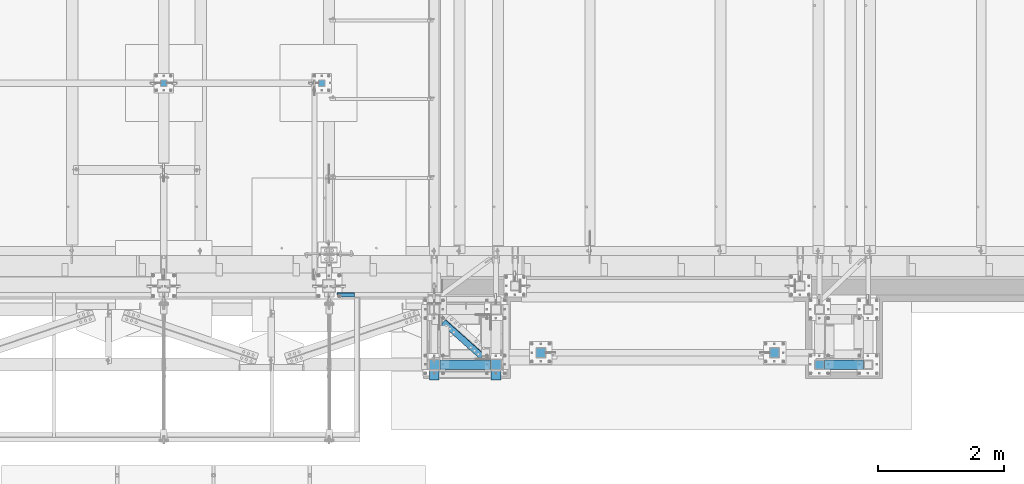
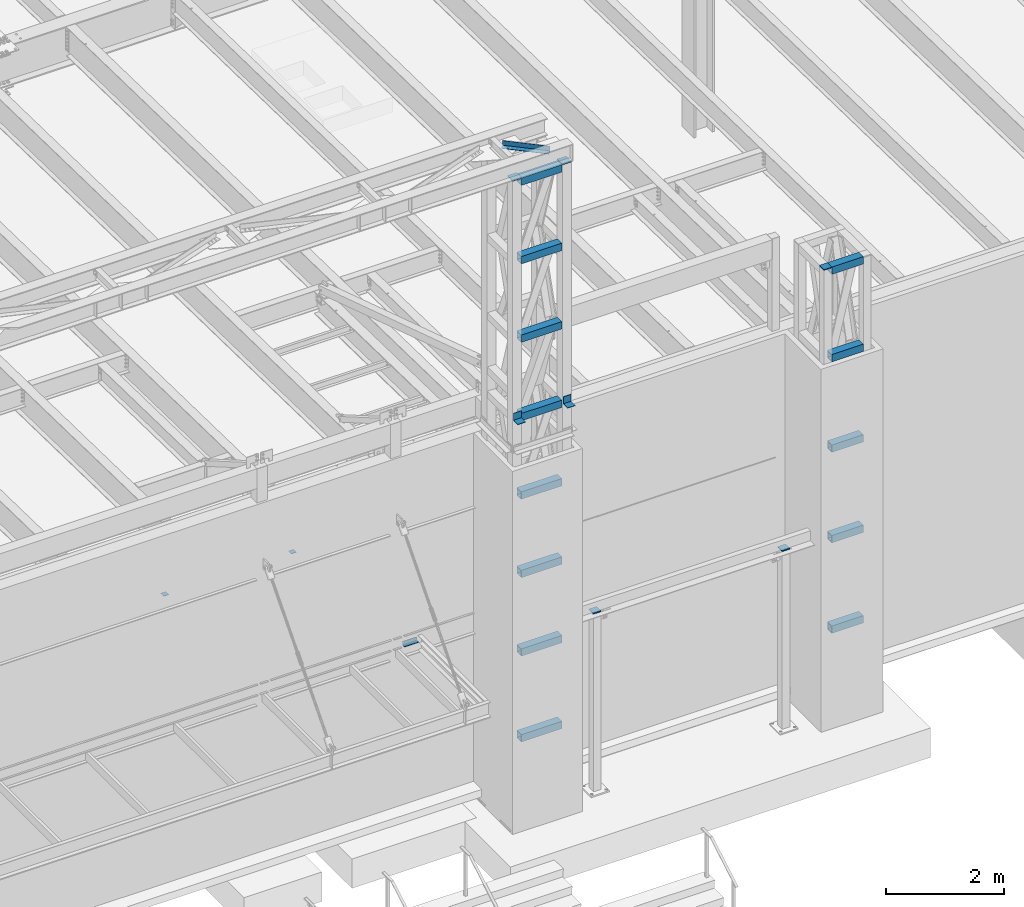
# One storey, part 1208 of 1763: 24 beams, 8 elements without a shape of their own.
"""IFC2X3 building model written with IfcOpenShell, lengths in millimetres."""

import ifcopenshell
import ifcopenshell.guid

model = None  # the IFC model being written
_history = None  # IfcOwnerHistory: only IFC2X3 demands one
_inside = {}  # id of a spatial element -> (the spatial element, [elements in it])
_under = {}  # id of a project, library or spatial element -> (it, [spatial elements below it])
_declared = {}  # id of a project -> (the project, [libraries it declares])
_typed = {}  # id of a type object -> (the type object, [elements of that type])
_made_of = {}  # id of a material, layer set ... -> (it, [elements and type objects made of it])


def new_model(schema):
    """Start an empty IFC model of exactly this schema.

    Asked for "IFC4X3", IfcOpenShell would pick the latest addendum, in which some entities
    have other attributes; the version numbers below select the first issue.
    IFC2X3 requires an IfcOwnerHistory on every rooted entity: one is made here for all.
    """
    global model, _history
    if schema == "IFC4X3":
        model = ifcopenshell.file(schema_version=(4, 3, 0, 0))
    else:
        model = ifcopenshell.file(schema=schema)
    _inside.clear()
    _under.clear()
    _declared.clear()
    _typed.clear()
    _made_of.clear()
    _history = None
    if model.schema == "IFC2X3":
        org = make("IfcOrganization", Name="unknown")
        user = make(
            "IfcPersonAndOrganization",
            ThePerson=make("IfcPerson", FamilyName="unknown"),
            TheOrganization=org,
        )
        app = make(
            "IfcApplication",
            ApplicationDeveloper=org,
            Version="unknown",
            ApplicationFullName="unknown",
            ApplicationIdentifier="unknown",
        )
        _history = make(
            "IfcOwnerHistory",
            OwningUser=user,
            OwningApplication=app,
            ChangeAction="ADDED",
            CreationDate=0,
        )
    return model


def make(cls, **values):
    """One entity of the class cls with the attributes given. An attribute that is None is left unset."""
    return model.create_entity(
        cls, **{name: value for name, value in values.items() if value is not None}
    )


def rooted(cls, **values):
    """An entity with a GlobalId (a new one), such as an element, a storey or a relation."""
    return make(cls, GlobalId=ifcopenshell.guid.new(), OwnerHistory=_history, **values)


def si_unit(unit_type, name, prefix=None):
    """IfcSIUnit, for example si_unit("LENGTHUNIT", "METRE", prefix="MILLI")."""
    return make("IfcSIUnit", UnitType=unit_type, Prefix=prefix, Name=name)


def assignment(units):
    """IfcUnitAssignment: the units of a project."""
    return None if units is None else make("IfcUnitAssignment", Units=units)


def point(xyz):
    """IfcCartesianPoint."""
    return None if xyz is None else make("IfcCartesianPoint", Coordinates=xyz)


def direction(xyz):
    """IfcDirection."""
    return None if xyz is None else make("IfcDirection", DirectionRatios=xyz)


def frame(location, z_axis=None, x_axis=None):
    """IfcAxis2Placement3D, a coordinate frame: its origin and axes. An axis left out is left unset."""
    return make(
        "IfcAxis2Placement3D",
        Location=point(location),
        Axis=direction(z_axis),
        RefDirection=direction(x_axis),
    )


def origin_with_axes():
    """The frame at (0, 0, 0) with the z axis (0, 0, 1) and the x axis (1, 0, 0) written out."""
    return frame((0.0, 0.0, 0.0), z_axis=(0.0, 0.0, 1.0), x_axis=(1.0, 0.0, 0.0))


def place(relative_to, where):
    """IfcLocalPlacement: puts the frame where relative to a parent placement (None: the world)."""
    return make(
        "IfcLocalPlacement", PlacementRelTo=relative_to, RelativePlacement=where
    )


def context(
    kind, dimensions, precision=None, world=None, true_north=None, identifier=None
):
    """IfcGeometricRepresentationContext, for example the 3D "Model" context."""
    return make(
        "IfcGeometricRepresentationContext",
        ContextIdentifier=identifier,
        ContextType=kind,
        CoordinateSpaceDimension=dimensions,
        Precision=precision,
        WorldCoordinateSystem=world,
        TrueNorth=true_north,
    )


def subcontext(parent, identifier, kind, view, scale=None):
    """IfcGeometricRepresentationSubContext, for example "Body" below "Model"."""
    return make(
        "IfcGeometricRepresentationSubContext",
        ContextIdentifier=identifier,
        ContextType=kind,
        ParentContext=parent,
        TargetScale=scale,
        TargetView=view,
    )


def project(units=None, contexts=None):
    """IfcProject with its units and contexts."""
    return rooted(
        "IfcProject",
        Name="project",
        RepresentationContexts=contexts,
        UnitsInContext=assignment(units),
    )


def spatial(cls, under=None, at=None, **own):
    """A site, building, storey or space (cls), placed at a placement, below another one or the project."""
    s = rooted(cls, ObjectPlacement=at, **own)
    if under is not None:
        _under.setdefault(under.id(), (under, []))[1].append(s)
    return s


def faces_of(points, faces, orient=None, outer=None):
    """IfcFace entities. A face is a list of loops; a loop is a list of indices into points, from 0.

    orient and outer hold one flag for each loop. By default every Orientation is true, the
    first loop of a face is its IfcFaceOuterBound and the others are IfcFaceBound.
    """
    made = []
    for i, loops in enumerate(faces):
        bounds = []
        for j, loop in enumerate(loops):
            is_outer = j == 0 if outer is None else outer[i][j]
            bounds.append(
                make(
                    "IfcFaceOuterBound" if is_outer else "IfcFaceBound",
                    Bound=make("IfcPolyLoop", Polygon=[points[k] for k in loop]),
                    Orientation=True if orient is None else orient[i][j],
                )
            )
        made.append(make("IfcFace", Bounds=bounds))
    return made


def faceted_brep(points, faces, orient=None, outer=None, voids=None):
    """IfcFacetedBrep: a solid bounded by flat faces; with voids (closed shells), ...WithVoids."""
    shared = [point(p) for p in points]
    hull = make("IfcClosedShell", CfsFaces=faces_of(shared, faces, orient, outer))
    if voids is None:
        return make("IfcFacetedBrep", Outer=hull)
    return make(
        "IfcFacetedBrepWithVoids",
        Outer=hull,
        Voids=[
            make(cls, CfsFaces=faces_of(shared, fs, o, b)) for cls, fs, o, b in voids
        ],
    )


def shape(context_of_items, identifier, shape_type, items):
    """IfcShapeRepresentation: the items that make up one representation, for example the "Body"."""
    return make(
        "IfcShapeRepresentation",
        ContextOfItems=context_of_items,
        RepresentationIdentifier=identifier,
        RepresentationType=shape_type,
        Items=items,
    )


def material(Name=None, Category=None):
    """IfcMaterial."""
    return make("IfcMaterial", Name=Name, Category=Category)


def made_of(thing, what):
    """Note that an element or type object is made of a material, layer set ...; save() writes the relation."""
    if what is not None:
        _made_of.setdefault(what.id(), (what, []))[1].append(thing)
    return thing


def type_object(cls, material=None, **own):
    """A type object (cls), such as IfcWallType, which elements share."""
    return made_of(rooted(cls, **own), material)


def element(
    cls,
    number,
    at=None,
    inside=None,
    cuts=None,
    type_object=None,
    material=None,
    context=None,
    identifier="Body",
    shape_type=None,
    held_by="IfcProductDefinitionShape",
    body=None,
    shapes=None,
    **own,
):
    """One element of the class cls, such as IfcWall. Its Tag is "e" and its number.

    at: its placement. inside: the storey or other place that contains it. cuts: it is an
    opening in that element (IfcRelVoidsElement). A single representation is given by context,
    identifier, shape_type and body (its items); several are given by shapes. held_by: the class
    of the entity that holds the representations. save() writes the other relations.
    """
    e = rooted(cls, Tag="e%d" % number, ObjectPlacement=at, **own)
    if body is not None:
        shapes = [shape(context, identifier, shape_type, body)]
    if shapes is not None:
        e.Representation = make(held_by, Representations=shapes)
    if inside is not None:
        _inside.setdefault(inside.id(), (inside, []))[1].append(e)
    if cuts is not None:
        rooted(
            "IfcRelVoidsElement", RelatingBuildingElement=cuts, RelatedOpeningElement=e
        )
    if type_object is not None:
        _typed.setdefault(type_object.id(), (type_object, []))[1].append(e)
    return made_of(e, material)


def aggregate(whole, parts):
    """IfcRelAggregates: a whole, such as a stair, and the parts it consists of."""
    return rooted("IfcRelAggregates", RelatingObject=whole, RelatedObjects=parts)


def save(model, path):
    """Write the relations noted so far, then the file.

    IfcRelAggregates (storeys below a building ...), IfcRelContainedInSpatialStructure (elements
    in a storey), IfcRelDefinesByType, IfcRelAssociatesMaterial and IfcRelDeclares: one each for
    every whole, place, type object, material and project.
    """
    for whole, parts in _under.values():
        aggregate(whole, parts)
    for where, things in _inside.values():
        rooted(
            "IfcRelContainedInSpatialStructure",
            RelatedElements=things,
            RelatingStructure=where,
        )
    for kind, things in _typed.values():
        rooted("IfcRelDefinesByType", RelatedObjects=things, RelatingType=kind)
    for what, things in _made_of.values():
        rooted("IfcRelAssociatesMaterial", RelatedObjects=things, RelatingMaterial=what)
    for by, libraries in _declared.values():
        rooted("IfcRelDeclares", RelatingContext=by, RelatedDefinitions=libraries)
    model.write(path)


model = new_model("IFC2X3")

# Units and contexts
model_context = context("Model", 3, precision=1e-05, world=origin_with_axes())
body_context = subcontext(model_context, "Body", "Model", "MODEL_VIEW")
ifc_project = project(units=[si_unit("LENGTHUNIT", "METRE", prefix="MILLI"), si_unit("AREAUNIT", "SQUARE_METRE"), si_unit("VOLUMEUNIT", "CUBIC_METRE"), si_unit("MASSUNIT", "GRAM", prefix="KILO"), si_unit("TIMEUNIT", "SECOND"), si_unit("PLANEANGLEUNIT", "RADIAN"), si_unit("SOLIDANGLEUNIT", "STERADIAN"), si_unit("THERMODYNAMICTEMPERATUREUNIT", "DEGREE_CELSIUS"), si_unit("LUMINOUSINTENSITYUNIT", "LUMEN")], contexts=[model_context])

# Site, building, storey
site_placement = place(None, origin_with_axes())
site = spatial("IfcSite", under=ifc_project, at=site_placement, CompositionType="ELEMENT")
building_placement = place(site_placement, origin_with_axes())
building = spatial("IfcBuilding", under=site, at=building_placement, Name="Undefined", CompositionType="ELEMENT")
storey_placement = place(building_placement, origin_with_axes())
storey = spatial("IfcBuildingStorey", under=building, at=storey_placement, Name="Undefined", CompositionType="ELEMENT", Elevation=0.0)

# Assembly, beam
assembly_1_placement = place(storey_placement, origin_with_axes())
assembly_1 = element("IfcElementAssembly", 1, at=assembly_1_placement, inside=storey, Name="ANGLE", AssemblyPlace="NOTDEFINED", PredefinedType="RIGID_FRAME")
ifc_material_1 = material(Name="STEEL/A36")
beam_type_1 = type_object("IfcBeamType", Name="L4X4X1/4", PredefinedType="NOTDEFINED")
beam_1_placement = place(assembly_1_placement, frame((-46794.6759782461, -15490.5665809142, 18672.175), z_axis=(-0.667212485940867, -0.744867436933988, 0.0), x_axis=(-0.744867436933987, 0.667212485940868, 0.0)))
beam_1 = element("IfcBeam", 2, at=beam_1_placement, type_object=beam_type_1, material=ifc_material_1, Name="ANGLE", ObjectType="L4X4X1/4", context=body_context, shape_type="Brep", body=[
    faceted_brep([(246.665849237292, -50.7999999999993, -44.4499999995605), (246.665849237281, -50.7999999999993, -50.7999999995518), (1070.58066999025, -50.7999999999993, -50.7999999982494), (1070.58066999025, -50.7999999999993, -44.4499999982581), (246.665849237292, 44.4500000000007, -44.4499999995605), (1070.58066999025, 44.4500000000007, -44.4499999982581), (246.665849237394, 44.4500000000007, 50.8000000003231), (1070.58066999036, 44.4500000000007, 50.8000000016327), (246.665849237394, 50.7999999999993, 50.8000000003231), (1070.58066999036, 50.7999999999993, 50.8000000016327), (246.665849237281, 50.7999999999993, -50.7999999995518), (1070.58066999025, 50.7999999999993, -50.7999999982494)], [[[0, 1, 2, 3]], [[4, 0, 3, 5]], [[6, 4, 5, 7]], [[8, 6, 7, 9]], [[1, 0, 4, 6, 8, 10]], [[1, 10, 11, 2]], [[7, 5, 3, 2, 11, 9]], [[10, 8, 9, 11]]]),
])
aggregate(assembly_1, [beam_1])

# Assembly, beams
assembly_2_placement = place(storey_placement, origin_with_axes())
assembly_2 = element("IfcElementAssembly", 3, at=assembly_2_placement, inside=storey, Name="FRAME", AssemblyPlace="NOTDEFINED", PredefinedType="RIGID_FRAME")
ifc_material_2 = material()
beam_type_2 = type_object("IfcBeamType", Name="HSS6X6X3/8", PredefinedType="NOTDEFINED")
beam_2_placement = place(assembly_2_placement, frame((-47735.5523997267, -15452.7272094127, 10248.70156), z_axis=(0.0, 0.0, 1.0), x_axis=(1.0, 0.0, 0.0)))
beam_2 = element("IfcBeam", 4, at=beam_2_placement, type_object=beam_type_2, material=ifc_material_2, Name="BEAM", ObjectType="HSS6X6X3/8", context=body_context, shape_type="Brep", body=[
    faceted_brep([(88.8999999999996, 66.6750000000029, -66.6749999999993), (88.8999999999996, -66.6750000000029, -66.6749999999993), (885.825195312507, -66.6749999999993, -66.6749999999993), (885.825158360378, 66.6749999998519, -66.6749999999993), (88.8999999999996, -66.6750000000029, 66.6749999999993), (885.825195312507, -66.6749999999993, 66.6749999999993), (88.8999999999996, 66.6750000000029, 66.6749999999993), (885.825158360378, 66.6749999998519, 66.6749999999993), (88.8999999999996, 76.1999999999971, -76.2000000000007), (88.8999999999996, 76.1999999999971, 76.2000000000007), (885.825180982218, 76.1999999998425, 76.2000000000007), (885.825180982218, 76.1999999998425, -76.2000000000007), (88.8999999999996, -76.1999999999971, 76.2000000000007), (885.825195312507, -76.2000000000007, 76.2000000000007), (88.8999999999996, -76.1999999999971, -76.2000000000007), (885.825195312507, -76.2000000000007, -76.2000000000007)], [[[0, 1, 2, 3]], [[1, 4, 5, 2]], [[4, 6, 7, 5]], [[6, 0, 3, 7]], [[8, 9, 10, 11]], [[9, 12, 13, 10]], [[12, 14, 15, 13]], [[14, 8, 11, 15]], [[13, 15, 11, 10], [5, 7, 3, 2]], [[14, 12, 9, 8], [6, 4, 1, 0]]]),
])
beam_3_placement = place(assembly_2_placement, frame((-47735.5523997267, -15452.7272094127, 11873.706248), z_axis=(0.0, 0.0, 1.0), x_axis=(1.0, 0.0, 0.0)))
beam_3 = element("IfcBeam", 5, at=beam_3_placement, type_object=beam_type_2, material=ifc_material_2, Name="BEAM", ObjectType="HSS6X6X3/8", context=body_context, shape_type="Brep", body=[
    faceted_brep([(88.8999999999996, 66.6750000000029, -66.6749999999993), (88.8999999999996, -66.6750000000029, -66.6749999999993), (885.825195312507, -66.6749999999993, -66.6749999999993), (885.825158360378, 66.6749999998519, -66.6749999999993), (88.8999999999996, -66.6750000000029, 66.6749999999993), (885.825195312507, -66.6749999999993, 66.6749999999993), (88.8999999999996, 66.6750000000029, 66.6749999999993), (885.825158360378, 66.6749999998519, 66.6749999999993), (88.8999999999996, 76.1999999999971, -76.2000000000007), (88.8999999999996, 76.1999999999971, 76.2000000000007), (885.825180982218, 76.1999999998425, 76.2000000000007), (885.825180982218, 76.1999999998425, -76.2000000000007), (88.8999999999996, -76.1999999999971, 76.2000000000007), (885.825195312507, -76.2000000000007, 76.2000000000007), (88.8999999999996, -76.1999999999971, -76.2000000000007), (885.825195312507, -76.2000000000007, -76.2000000000007)], [[[0, 1, 2, 3]], [[1, 4, 5, 2]], [[4, 6, 7, 5]], [[6, 0, 3, 7]], [[8, 9, 10, 11]], [[9, 12, 13, 10]], [[12, 14, 15, 13]], [[14, 8, 11, 15]], [[13, 15, 11, 10], [5, 7, 3, 2]], [[14, 12, 9, 8], [6, 4, 1, 0]]]),
])
beam_4_placement = place(assembly_2_placement, frame((-47735.5523997267, -15452.7272094127, 13498.710936), z_axis=(0.0, 0.0, 1.0), x_axis=(1.0, 0.0, 0.0)))
beam_4 = element("IfcBeam", 6, at=beam_4_placement, type_object=beam_type_2, material=ifc_material_2, Name="BEAM", ObjectType="HSS6X6X3/8", context=body_context, shape_type="Brep", body=[
    faceted_brep([(88.8999999999996, 66.6750000000029, -66.6749999999993), (88.8999999999996, -66.6750000000029, -66.6749999999993), (885.825195312507, -66.6749999999993, -66.6749999999993), (885.825158360378, 66.6749999998519, -66.6749999999993), (88.8999999999996, -66.6750000000029, 66.6749999999993), (885.825195312507, -66.6749999999993, 66.6749999999993), (88.8999999999996, 66.6750000000029, 66.6749999999993), (885.825158360378, 66.6749999998519, 66.6749999999993), (88.8999999999996, 76.1999999999971, -76.2000000000007), (88.8999999999996, 76.1999999999971, 76.2000000000007), (885.825180982218, 76.1999999998425, 76.2000000000007), (885.825180982218, 76.1999999998425, -76.2000000000007), (88.8999999999996, -76.1999999999971, 76.2000000000007), (885.825195312507, -76.2000000000007, 76.2000000000007), (88.8999999999996, -76.1999999999971, -76.2000000000007), (885.825195312507, -76.2000000000007, -76.2000000000007)], [[[0, 1, 2, 3]], [[1, 4, 5, 2]], [[4, 6, 7, 5]], [[6, 0, 3, 7]], [[8, 9, 10, 11]], [[9, 12, 13, 10]], [[12, 14, 15, 13]], [[14, 8, 11, 15]], [[13, 15, 11, 10], [5, 7, 3, 2]], [[14, 12, 9, 8], [6, 4, 1, 0]]]),
])
beam_5_placement = place(assembly_2_placement, frame((-47735.5523997267, -15452.7272094127, 15123.715624), z_axis=(0.0, 0.0, 1.0), x_axis=(1.0, 0.0, 0.0)))
beam_5 = element("IfcBeam", 7, at=beam_5_placement, type_object=beam_type_2, material=ifc_material_2, Name="BEAM", ObjectType="HSS6X6X3/8", context=body_context, shape_type="Brep", body=[
    faceted_brep([(88.8999999999996, 66.6750000000029, -66.6749999999993), (88.8999999999996, -66.6750000000029, -66.6749999999993), (885.825195312507, -66.6749999999993, -66.6749999999993), (885.825158360378, 66.6749999998519, -66.6749999999993), (88.8999999999996, -66.6750000000029, 66.6749999999993), (885.825195312507, -66.6749999999993, 66.6749999999993), (88.8999999999996, 66.6750000000029, 66.6749999999993), (885.825158360378, 66.6749999998519, 66.6749999999993), (88.8999999999996, 76.1999999999971, -76.2000000000007), (88.8999999999996, 76.1999999999971, 76.2000000000007), (885.825180982218, 76.1999999998425, 76.2000000000007), (885.825180982218, 76.1999999998425, -76.2000000000007), (88.8999999999996, -76.1999999999971, 76.2000000000007), (885.825195312507, -76.2000000000007, 76.2000000000007), (88.8999999999996, -76.1999999999971, -76.2000000000007), (885.825195312507, -76.2000000000007, -76.2000000000007)], [[[0, 1, 2, 3]], [[1, 4, 5, 2]], [[4, 6, 7, 5]], [[6, 0, 3, 7]], [[8, 9, 10, 11]], [[9, 12, 13, 10]], [[12, 14, 15, 13]], [[14, 8, 11, 15]], [[13, 15, 11, 10], [5, 7, 3, 2]], [[14, 12, 9, 8], [6, 4, 1, 0]]]),
])
beam_6_placement = place(assembly_2_placement, frame((-47735.5523997267, -15452.7272094127, 16748.720312), z_axis=(0.0, 0.0, 1.0), x_axis=(1.0, 0.0, 0.0)))
beam_6 = element("IfcBeam", 8, at=beam_6_placement, type_object=beam_type_2, material=ifc_material_2, Name="BEAM", ObjectType="HSS6X6X3/8", context=body_context, shape_type="Brep", body=[
    faceted_brep([(88.8999999999996, 66.6750000000029, -66.6749999999993), (88.8999999999996, -66.6750000000029, -66.6749999999993), (885.825195312507, -66.6749999999993, -66.6749999999993), (885.825158360378, 66.6749999998519, -66.6749999999993), (88.8999999999996, -66.6750000000029, 66.6749999999993), (885.825195312507, -66.6749999999993, 66.6749999999993), (88.8999999999996, 66.6750000000029, 66.6749999999993), (885.825158360378, 66.6749999998519, 66.6749999999993), (88.8999999999996, 76.1999999999971, -76.2000000000007), (88.8999999999996, 76.1999999999971, 76.2000000000007), (885.825180982218, 76.1999999998425, 76.2000000000007), (885.825180982218, 76.1999999998425, -76.2000000000007), (88.8999999999996, -76.1999999999971, 76.2000000000007), (885.825195312507, -76.2000000000007, 76.2000000000007), (88.8999999999996, -76.1999999999971, -76.2000000000007), (885.825195312507, -76.2000000000007, -76.2000000000007)], [[[0, 1, 2, 3]], [[1, 4, 5, 2]], [[4, 6, 7, 5]], [[6, 0, 3, 7]], [[8, 9, 10, 11]], [[9, 12, 13, 10]], [[12, 14, 15, 13]], [[14, 8, 11, 15]], [[13, 15, 11, 10], [5, 7, 3, 2]], [[14, 12, 9, 8], [6, 4, 1, 0]]]),
])
beam_7_placement = place(assembly_2_placement, frame((-47735.5523997267, -15452.7272094127, 18373.725), z_axis=(0.0, 0.0, 1.0), x_axis=(1.0, 0.0, 0.0)))
beam_7 = element("IfcBeam", 9, at=beam_7_placement, type_object=beam_type_2, material=ifc_material_2, Name="BEAM", ObjectType="HSS6X6X3/8", context=body_context, shape_type="Brep", body=[
    faceted_brep([(88.8999999999996, 66.6750000000029, -66.6749999999993), (88.8999999999996, -66.6750000000029, -66.6749999999993), (885.825195312507, -66.6749999999993, -66.6749999999993), (885.825158360378, 66.6749999998519, -66.6749999999993), (88.8999999999996, -66.6750000000029, 66.6749999999993), (885.825195312507, -66.6749999999993, 66.6749999999993), (88.8999999999996, 66.6750000000029, 66.6749999999993), (885.825158360378, 66.6749999998519, 66.6749999999993), (88.8999999999996, 76.1999999999971, -76.2000000000007), (88.8999999999996, 76.1999999999971, 76.2000000000007), (885.825180982218, 76.1999999998425, 76.2000000000007), (885.825180982218, 76.1999999998425, -76.2000000000007), (88.8999999999996, -76.1999999999971, 76.2000000000007), (885.825195312507, -76.2000000000007, 76.2000000000007), (88.8999999999996, -76.1999999999971, -76.2000000000007), (885.825195312507, -76.2000000000007, -76.2000000000007)], [[[0, 1, 2, 3]], [[1, 4, 5, 2]], [[4, 6, 7, 5]], [[6, 0, 3, 7]], [[8, 9, 10, 11]], [[9, 12, 13, 10]], [[12, 14, 15, 13]], [[14, 8, 11, 15]], [[13, 15, 11, 10], [5, 7, 3, 2]], [[14, 12, 9, 8], [6, 4, 1, 0]]]),
])
beam_8_placement = place(assembly_2_placement, frame((-47735.5523997267, -15452.7272094127, 8623.3), z_axis=(0.0, 0.0, 1.0), x_axis=(1.0, 0.0, 0.0)))
beam_8 = element("IfcBeam", 10, at=beam_8_placement, type_object=beam_type_2, material=ifc_material_2, Name="BEAM", ObjectType="HSS6X6X3/8", context=body_context, shape_type="Brep", body=[
    faceted_brep([(88.8999999999996, 66.6750000000029, -66.6749999999993), (88.8999999999996, -66.6750000000029, -66.6749999999993), (885.825195312507, -66.6749999999993, -66.6749999999993), (885.825158360378, 66.6749999998519, -66.6749999999993), (88.8999999999996, -66.6750000000029, 66.6749999999993), (885.825195312507, -66.6749999999993, 66.6749999999993), (88.8999999999996, 66.6750000000029, 66.6749999999993), (885.825158360378, 66.6749999998519, 66.6749999999993), (88.8999999999996, 76.1999999999971, -76.2000000000007), (88.8999999999996, 76.1999999999971, 76.2000000000007), (885.825180982218, 76.1999999998425, 76.2000000000007), (885.825180982218, 76.1999999998425, -76.2000000000007), (88.8999999999996, -76.1999999999971, 76.2000000000007), (885.825195312507, -76.2000000000007, 76.2000000000007), (88.8999999999996, -76.1999999999971, -76.2000000000007), (885.825195312507, -76.2000000000007, -76.2000000000007)], [[[0, 1, 2, 3]], [[1, 4, 5, 2]], [[4, 6, 7, 5]], [[6, 0, 3, 7]], [[8, 9, 10, 11]], [[9, 12, 13, 10]], [[12, 14, 15, 13]], [[14, 8, 11, 15]], [[13, 15, 11, 10], [5, 7, 3, 2]], [[14, 12, 9, 8], [6, 4, 1, 0]]]),
])
beam_9_placement = place(assembly_2_placement, frame((-47735.5523997267, -15452.7272094127, 6845.3), z_axis=(0.0, 0.0, 1.0), x_axis=(1.0, 0.0, 0.0)))
beam_9 = element("IfcBeam", 11, at=beam_9_placement, type_object=beam_type_2, material=ifc_material_2, Name="BEAM", ObjectType="HSS6X6X3/8", context=body_context, shape_type="Brep", body=[
    faceted_brep([(88.8999999999996, 66.6750000000029, -66.6749999999993), (88.8999999999996, -66.6750000000029, -66.6749999999993), (885.825195312507, -66.6749999999993, -66.6749999999993), (885.825158360378, 66.6749999998519, -66.6749999999993), (88.8999999999996, -66.6750000000029, 66.6749999999993), (885.825195312507, -66.6749999999993, 66.6749999999993), (88.8999999999996, 66.6750000000029, 66.6749999999993), (885.825158360378, 66.6749999998519, 66.6749999999993), (88.8999999999996, 76.1999999999971, -76.2000000000007), (88.8999999999996, 76.1999999999971, 76.2000000000007), (885.825180982218, 76.1999999998425, 76.2000000000007), (885.825180982218, 76.1999999998425, -76.2000000000007), (88.8999999999996, -76.1999999999971, 76.2000000000007), (885.825195312507, -76.2000000000007, 76.2000000000007), (88.8999999999996, -76.1999999999971, -76.2000000000007), (885.825195312507, -76.2000000000007, -76.2000000000007)], [[[0, 1, 2, 3]], [[1, 4, 5, 2]], [[4, 6, 7, 5]], [[6, 0, 3, 7]], [[8, 9, 10, 11]], [[9, 12, 13, 10]], [[12, 14, 15, 13]], [[14, 8, 11, 15]], [[13, 15, 11, 10], [5, 7, 3, 2]], [[14, 12, 9, 8], [6, 4, 1, 0]]]),
])

# Assembly, beam
assembly_3_placement = place(storey_placement, origin_with_axes())
assembly_3 = element("IfcElementAssembly", 12, at=assembly_3_placement, inside=storey, Name="FRAME", AssemblyPlace="NOTDEFINED", PredefinedType="RIGID_FRAME")
beam_type_3 = type_object("IfcBeamType", PredefinedType="NOTDEFINED")
beam_10_placement = place(assembly_3_placement, frame((-41639.5634959181, -15528.8556029674, 14468.475), z_axis=(1.0, 0.0, 0.0), x_axis=(0.0, 1.0, 0.0)))
beam_10 = element("IfcBeam", 13, at=beam_10_placement, type_object=beam_type_3, material=ifc_material_1, Name="PLATE", context=body_context, shape_type="Brep", body=[
    faceted_brep([(0.0, 9.52499999999964, -76.1999999999971), (0.0, 9.52499999999964, 76.1999999999971), (152.400000000001, 9.52499999999964, 76.1999999999971), (152.400000000001, 9.52499999999964, -76.1999999999971), (0.0, -9.52499999999964, 76.1999999999971), (152.400000000001, -9.52499999999964, 76.1999999999971), (0.0, -9.52499999999964, -76.1999999999971), (152.400000000001, -9.52499999999964, -76.1999999999971)], [[[0, 1, 2, 3]], [[1, 4, 5, 2]], [[4, 6, 7, 5]], [[6, 0, 3, 7]], [[5, 7, 3, 2]], [[6, 4, 1, 0]]]),
])

assembly_4_placement = place(storey_placement, origin_with_axes())
assembly_4 = element("IfcElementAssembly", 14, at=assembly_4_placement, inside=storey, Name="COLUMN", AssemblyPlace="NOTDEFINED", PredefinedType="RIGID_FRAME")
beam_11_placement = place(assembly_4_placement, frame((-42351.1710444319, -15341.6000613784, 8778.875), z_axis=(1.0, 0.0, 0.0), x_axis=(0.0, 1.0, 0.0)))
beam_11 = element("IfcBeam", 15, at=beam_11_placement, type_object=beam_type_3, material=ifc_material_1, Name="PLATE", context=body_context, shape_type="Brep", body=[
    faceted_brep([(0.0, 9.52499999999964, -76.1999999999971), (0.0, 9.52499999999964, 76.1999999999971), (152.400000000001, 9.52499999999964, 76.1999999999971), (152.400000000001, 9.52499999999964, -76.1999999999971), (0.0, -9.52499999999964, 76.1999999999971), (152.400000000001, -9.52499999999964, 76.1999999999971), (0.0, -9.52499999999964, -76.1999999999971), (152.400000000001, -9.52499999999964, -76.1999999999971)], [[[0, 1, 2, 3]], [[1, 4, 5, 2]], [[4, 6, 7, 5]], [[6, 0, 3, 7]], [[5, 7, 3, 2]], [[6, 4, 1, 0]]]),
])
aggregate(assembly_4, [beam_11])

assembly_5_placement = place(storey_placement, origin_with_axes())
assembly_5 = element("IfcElementAssembly", 16, at=assembly_5_placement, inside=storey, Name="COLUMN", AssemblyPlace="NOTDEFINED", PredefinedType="RIGID_FRAME")
beam_12_placement = place(assembly_5_placement, frame((-46049.6371287306, -15341.6000613784, 8778.875), z_axis=(1.0, 0.0, 0.0), x_axis=(0.0, 1.0, 0.0)))
beam_12 = element("IfcBeam", 17, at=beam_12_placement, type_object=beam_type_3, material=ifc_material_1, Name="PLATE", context=body_context, shape_type="Brep", body=[
    faceted_brep([(0.0, 9.52499999999964, -76.1999999999971), (0.0, 9.52499999999964, 76.1999999999971), (152.400000000001, 9.52499999999964, 76.1999999999971), (152.400000000001, 9.52499999999964, -76.1999999999971), (0.0, -9.52499999999964, 76.1999999999971), (152.400000000001, -9.52499999999964, 76.1999999999971), (0.0, -9.52499999999964, -76.1999999999971), (152.400000000001, -9.52499999999964, -76.1999999999971)], [[[0, 1, 2, 3]], [[1, 4, 5, 2]], [[4, 6, 7, 5]], [[6, 0, 3, 7]], [[5, 7, 3, 2]], [[6, 4, 1, 0]]]),
])
aggregate(assembly_5, [beam_12])

# Beam
beam_type_4 = type_object("IfcBeamType", Name="HSS6X6X5/8", PredefinedType="NOTDEFINED")
beam_13_placement = place(assembly_3_placement, frame((-41639.5633006091, -15452.6556029674, 6966.74375), z_axis=(0.0, 0.0, 1.0), x_axis=(1.0, 0.0, 0.0)))
beam_13 = element("IfcBeam", 18, at=beam_13_placement, type_object=beam_type_4, material=ifc_material_2, Name="BEAM", ObjectType="HSS6X6X5/8", context=body_context, shape_type="Brep", body=[
    faceted_brep([(76.1998535156017, 60.3250000000007, -60.3249999999998), (76.1998535156017, -60.3250000000007, -60.3249999999998), (695.325048828119, -60.3250000000007, -60.3249999999998), (695.325048828119, 60.3250000000007, -60.3249999999998), (76.1998535156017, -60.3250000000007, 60.3249999999998), (695.325048828119, -60.3250000000007, 60.3249999999998), (76.1998535156017, 60.3250000000007, 60.3249999999998), (695.325048828119, 60.3250000000007, 60.3249999999998), (76.1998535156017, 76.2000000000007, -76.1999999999998), (76.1998535156017, 76.2000000000007, 76.1999999999998), (695.325048828119, 76.2000000000007, 76.1999999999998), (695.325048828119, 76.2000000000007, -76.1999999999998), (76.1998535156017, -76.2000000000007, 76.1999999999998), (695.325048828119, -76.2000000000007, 76.1999999999998), (76.1998535156017, -76.2000000000007, -76.1999999999998), (695.325048828119, -76.2000000000007, -76.1999999999998)], [[[0, 1, 2, 3]], [[1, 4, 5, 2]], [[4, 6, 7, 5]], [[6, 0, 3, 7]], [[8, 9, 10, 11]], [[9, 12, 13, 10]], [[12, 14, 15, 13]], [[14, 8, 11, 15]], [[13, 15, 11, 10], [5, 7, 3, 2]], [[14, 12, 9, 8], [6, 4, 1, 0]]]),
])

beam_14_placement = place(assembly_3_placement, frame((-41639.5633006125, -15452.6556029674, 8840.7875), z_axis=(0.0, 0.0, 1.0), x_axis=(1.0, 0.0, 0.0)))
beam_14 = element("IfcBeam", 19, at=beam_14_placement, type_object=beam_type_4, material=ifc_material_2, Name="BEAM", ObjectType="HSS6X6X5/8", context=body_context, shape_type="Brep", body=[
    faceted_brep([(76.1999511718459, 60.3250000000007, -60.3250000000007), (76.1999511718459, -60.3250000000007, -60.3250000000007), (695.325146484363, -60.3250000000007, -60.3250000000007), (695.325146484363, 60.3250000000007, -60.3250000000007), (76.1999511718459, -60.3250000000007, 60.3250000000007), (695.325146484363, -60.3250000000007, 60.3250000000007), (76.1999511718459, 60.3250000000007, 60.3250000000007), (695.325146484363, 60.3250000000007, 60.3250000000007), (76.1999511718459, 76.2000000000007, -76.2000000000007), (76.1999511718459, 76.2000000000007, 76.2000000000007), (695.325146484363, 76.2000000000007, 76.2000000000007), (695.325146484363, 76.2000000000007, -76.2000000000007), (76.1999511718459, -76.2000000000007, 76.2000000000007), (695.325146484363, -76.2000000000007, 76.2000000000007), (76.1999511718459, -76.2000000000007, -76.2000000000007), (695.325146484363, -76.2000000000007, -76.2000000000007)], [[[0, 1, 2, 3]], [[1, 4, 5, 2]], [[4, 6, 7, 5]], [[6, 0, 3, 7]], [[8, 9, 10, 11]], [[9, 12, 13, 10]], [[12, 14, 15, 13]], [[14, 8, 11, 15]], [[13, 15, 11, 10], [5, 7, 3, 2]], [[14, 12, 9, 8], [6, 4, 1, 0]]]),
])

beam_15_placement = place(assembly_3_placement, frame((-41639.5633006159, -15452.6556029674, 10714.83125), z_axis=(0.0, 0.0, 1.0), x_axis=(1.0, 0.0, 0.0)))
beam_15 = element("IfcBeam", 20, at=beam_15_placement, type_object=beam_type_4, material=ifc_material_2, Name="BEAM", ObjectType="HSS6X6X5/8", context=body_context, shape_type="Brep", body=[
    faceted_brep([(76.1999511718459, 60.3250000000007, -60.3250000000007), (76.1999511718459, -60.3250000000007, -60.3250000000007), (695.325146484363, -60.3250000000007, -60.3250000000007), (695.325146484363, 60.3250000000007, -60.3250000000007), (76.1999511718459, -60.3250000000007, 60.3250000000007), (695.325146484363, -60.3250000000007, 60.3250000000007), (76.1999511718459, 60.3250000000007, 60.3250000000007), (695.325146484363, 60.3250000000007, 60.3250000000007), (76.1999511718459, 76.2000000000007, -76.2000000000007), (76.1999511718459, 76.2000000000007, 76.2000000000007), (695.325146484363, 76.2000000000007, 76.2000000000007), (695.325146484363, 76.2000000000007, -76.2000000000007), (76.1999511718459, -76.2000000000007, 76.2000000000007), (695.325146484363, -76.2000000000007, 76.2000000000007), (76.1999511718459, -76.2000000000007, -76.2000000000007), (695.325146484363, -76.2000000000007, -76.2000000000007)], [[[0, 1, 2, 3]], [[1, 4, 5, 2]], [[4, 6, 7, 5]], [[6, 0, 3, 7]], [[8, 9, 10, 11]], [[9, 12, 13, 10]], [[12, 14, 15, 13]], [[14, 8, 11, 15]], [[13, 15, 11, 10], [5, 7, 3, 2]], [[14, 12, 9, 8], [6, 4, 1, 0]]]),
])

beam_16_placement = place(assembly_3_placement, frame((-41639.5633006226, -15452.6556029674, 14401.8), z_axis=(0.0, 0.0, 1.0), x_axis=(1.0, 0.0, 0.0)))
beam_16 = element("IfcBeam", 21, at=beam_16_placement, type_object=beam_type_4, material=ifc_material_2, Name="BEAM", ObjectType="HSS6X6X5/8", context=body_context, shape_type="Brep", body=[
    faceted_brep([(76.1999511718459, 60.3250000000007, -60.3250000000007), (76.1999511718459, -60.3250000000007, -60.3250000000007), (695.325146484363, -60.3250000000007, -60.3250000000007), (695.325146484363, 60.3250000000007, -60.3250000000007), (76.2000027795075, -60.3250000000007, 60.3250000000007), (695.32519809201, -60.3250000000007, 60.3250000000007), (76.2000027795075, 60.3250000000007, 60.3250000000007), (695.32519809201, 60.3250000000007, 60.3250000000007), (76.1999511718459, 76.2000000000007, -76.2000000000007), (76.2000031128846, 76.2000000000007, 76.2000000000007), (695.325198425387, 76.2000000000007, 76.2000000000007), (695.325146484363, 76.2000000000007, -76.2000000000007), (76.2000031128846, -76.2000000000007, 76.2000000000007), (695.325198425387, -76.2000000000007, 76.2000000000007), (76.1999511718459, -76.2000000000007, -76.2000000000007), (695.325146484363, -76.2000000000007, -76.2000000000007)], [[[0, 1, 2, 3]], [[1, 4, 5, 2]], [[4, 6, 7, 5]], [[6, 0, 3, 7]], [[8, 9, 10, 11]], [[9, 12, 13, 10]], [[12, 14, 15, 13]], [[14, 8, 11, 15]], [[13, 15, 11, 10], [5, 7, 3, 2]], [[14, 12, 9, 8], [6, 4, 1, 0]]]),
])

beam_17_placement = place(assembly_3_placement, frame((-41639.5633006194, -15452.6556029674, 12588.875), z_axis=(0.0, 0.0, 1.0), x_axis=(1.0, 0.0, 0.0)))
beam_17 = element("IfcBeam", 22, at=beam_17_placement, type_object=beam_type_4, material=ifc_material_2, Name="BEAM", ObjectType="HSS6X6X5/8", context=body_context, shape_type="Brep", body=[
    faceted_brep([(76.1999511718459, 60.3250000000007, -60.3250000000007), (76.1999511718459, -60.3250000000007, -60.3250000000007), (695.325146484363, -60.3250000000007, -60.3250000000007), (695.325146484363, 60.3250000000007, -60.3250000000007), (76.2000027795075, -60.3250000000007, 60.3250000000007), (695.32519809201, -60.3250000000007, 60.3250000000007), (76.2000027795075, 60.3250000000007, 60.3250000000007), (695.32519809201, 60.3250000000007, 60.3250000000007), (76.1999511718459, 76.2000000000007, -76.2000000000007), (76.2000031128846, 76.2000000000007, 76.2000000000007), (695.325198425387, 76.2000000000007, 76.2000000000007), (695.325146484363, 76.2000000000007, -76.2000000000007), (76.2000031128846, -76.2000000000007, 76.2000000000007), (695.325198425387, -76.2000000000007, 76.2000000000007), (76.1999511718459, -76.2000000000007, -76.2000000000007), (695.325146484363, -76.2000000000007, -76.2000000000007)], [[[0, 1, 2, 3]], [[1, 4, 5, 2]], [[4, 6, 7, 5]], [[6, 0, 3, 7]], [[8, 9, 10, 11]], [[9, 12, 13, 10]], [[12, 14, 15, 13]], [[14, 8, 11, 15]], [[13, 15, 11, 10], [5, 7, 3, 2]], [[14, 12, 9, 8], [6, 4, 1, 0]]]),
])

aggregate(assembly_3, [beam_13, beam_14, beam_15, beam_16, beam_17, beam_10])

beam_type_5 = type_object("IfcBeamType", PredefinedType="NOTDEFINED")
beam_18_placement = place(assembly_2_placement, frame((-46760.8272044142, -15546.3897094127, 13649.3249938965), z_axis=(1.0, 0.0, 0.0), x_axis=(0.0, 0.0, -1.0)))
beam_18 = element("IfcBeam", 23, at=beam_18_placement, type_object=beam_type_5, material=ifc_material_1, Name="BENT_PLATE", context=body_context, shape_type="Brep", body=[
    faceted_brep([(0.0, -4.76250000000073, -76.1999999999971), (0.0, -4.76250000000073, 76.1999969482422), (0.0, 4.76250000000073, 76.1999969482422), (0.0, 4.76250000000073, -76.1999999999971), (152.399993896484, 4.76250000000073, 76.1999999999971), (152.399993896484, 4.76250000000073, -76.1999999999971), (142.874993896483, -4.76250000000073, -76.1999999999971), (142.874993896483, -4.76250000000073, 76.1999999999971), (152.399993896484, -147.637493896484, 76.1999999999971), (152.399993896484, -147.637493896484, -76.1999999999971), (142.874993896483, -147.637493896484, 76.1999999999971), (142.874993896483, -147.637493896484, -76.1999999999971)], [[[0, 1, 2, 3]], [[3, 2, 4, 5]], [[1, 0, 6, 7]], [[5, 4, 8, 9]], [[4, 2, 1, 7, 10, 8]], [[7, 6, 11, 10]], [[6, 0, 3, 5, 9, 11]], [[10, 11, 9, 8]]]),
])

beam_19_placement = place(assembly_2_placement, frame((-47735.5523997267, -15546.3897094127, 13649.325), z_axis=(1.0, 0.0, 0.0), x_axis=(0.0, 0.0, -1.0)))
beam_19 = element("IfcBeam", 24, at=beam_19_placement, type_object=beam_type_5, material=ifc_material_1, Name="BENT_PLATE", context=body_context, shape_type="Brep", body=[
    faceted_brep([(0.0, -4.76250000000073, -76.1999999999971), (0.0, -4.76250000000073, 76.1999969482422), (0.0, 4.76250000000073, 76.1999969482422), (0.0, 4.76250000000073, -76.1999999999971), (152.399993896484, 4.76250000000073, 76.1999999999971), (152.399993896484, 4.76250000000073, -76.1999999999971), (142.874993896483, -4.76250000000073, -76.1999999999971), (142.874993896483, -4.76250000000073, 76.1999999999971), (152.399993896484, -147.637493896484, 76.1999999999971), (152.399993896484, -147.637493896484, -76.1999999999971), (142.874993896483, -147.637493896484, 76.1999999999971), (142.874993896483, -147.637493896484, -76.1999999999971)], [[[0, 1, 2, 3]], [[3, 2, 4, 5]], [[1, 0, 6, 7]], [[5, 4, 8, 9]], [[4, 2, 1, 7, 10, 8]], [[7, 6, 11, 10]], [[6, 0, 3, 5, 9, 11]], [[10, 11, 9, 8]]]),
])

# Assembly, beam
assembly_6_placement = place(storey_placement, origin_with_axes())
assembly_6 = element("IfcElementAssembly", 25, at=assembly_6_placement, inside=storey, Name="BEAM", AssemblyPlace="NOTDEFINED", PredefinedType="RIGID_FRAME")
beam_type_6 = type_object("IfcBeamType", Name="L3X3X3/8", PredefinedType="NOTDEFINED")
beam_20_placement = place(assembly_6_placement, frame((-48996.0269591985, -14347.8275730615, 8648.7), z_axis=(0.0, -1.0, 0.0), x_axis=(-1.0, 0.0, 0.0)))
beam_20 = element("IfcBeam", 26, at=beam_20_placement, type_object=beam_type_6, material=ifc_material_1, Name="ANGLE", ObjectType="L3X3X3/8", context=body_context, shape_type="Brep", body=[
    faceted_brep([(0.0, 38.0999999999985, -38.1000000000004), (0.0, 38.0999999999985, 38.1000000000004), (279.39999999998, 38.1000000000004, 38.0999999999894), (279.39999999998, 38.1000000000004, -38.1000000000113), (1.45519152283669e-11, 28.5750000000007, 38.1000000000022), (279.39999999998, 28.5750000000007, 38.0999999999894), (0.0, 28.5750000000007, -28.5750000000007), (279.39999999998, 28.5750000000007, -28.5750000000116), (0.0, -38.1000000000004, -28.5750000000007), (279.39999999998, -38.1000000000004, -28.5750000000116), (0.0, -38.0999999999985, -38.1000000000004), (279.39999999998, -38.1000000000004, -38.1000000000113)], [[[0, 1, 2, 3]], [[1, 4, 5, 2]], [[4, 6, 7, 5]], [[6, 8, 9, 7]], [[8, 10, 11, 9]], [[10, 0, 3, 11]], [[5, 7, 9, 11, 3, 2]], [[10, 8, 6, 4, 1, 0]]]),
])
aggregate(assembly_6, [beam_20])

assembly_7_placement = place(storey_placement, origin_with_axes())
assembly_7 = element("IfcElementAssembly", 27, at=assembly_7_placement, inside=storey, Name="COLUMN", AssemblyPlace="NOTDEFINED", PredefinedType="RIGID_FRAME")
beam_type_7 = type_object("IfcBeamType", PredefinedType="NOTDEFINED")
beam_21_placement = place(assembly_7_placement, frame((-49516.7540133289, -11048.9999679201, 8620.12500000128), z_axis=(1.0, 0.0, 0.0), x_axis=(0.0, 1.0, 0.0)))
beam_21 = element("IfcBeam", 28, at=beam_21_placement, type_object=beam_type_7, material=ifc_material_1, Name="PLATE", context=body_context, shape_type="Brep", body=[
    faceted_brep([(0.0, 3.17500000000291, -50.7999999999993), (0.0, 3.17500000000291, 50.7999992370605), (101.599998474121, 3.17500000000291, 50.7999992370605), (101.599999999999, 3.17499999999927, -50.8000000000029), (0.0, -3.17500000000291, 50.7999992370605), (101.599998474121, -3.17500000000291, 50.7999992370605), (0.0, -3.17500000000291, -50.7999999999993), (101.599999999999, -3.17499999999927, -50.8000000000029)], [[[0, 1, 2, 3]], [[4, 5, 2, 1]], [[4, 6, 7, 5]], [[6, 0, 3, 7]], [[5, 7, 3, 2]], [[6, 4, 1, 0]]]),
])
aggregate(assembly_7, [beam_21])

assembly_8_placement = place(storey_placement, origin_with_axes())
assembly_8 = element("IfcElementAssembly", 29, at=assembly_8_placement, inside=storey, Name="COLUMN", AssemblyPlace="NOTDEFINED", PredefinedType="RIGID_FRAME")
beam_22_placement = place(assembly_8_placement, frame((-52018.6372736983, -11048.9999679201, 8620.12500000128), z_axis=(1.0, 0.0, 0.0), x_axis=(0.0, 1.0, 0.0)))
beam_22 = element("IfcBeam", 30, at=beam_22_placement, type_object=beam_type_7, material=ifc_material_1, Name="PLATE", context=body_context, shape_type="Brep", body=[
    faceted_brep([(0.0, 3.17500000000291, -50.7999999999993), (0.0, 3.17500000000291, 50.7999992370605), (101.599998474121, 3.17500000000291, 50.7999992370605), (101.599999999999, 3.17499999999927, -50.8000000000029), (0.0, -3.17500000000291, 50.7999992370605), (101.599998474121, -3.17500000000291, 50.7999992370605), (0.0, -3.17500000000291, -50.7999999999993), (101.599999999999, -3.17499999999927, -50.8000000000029)], [[[0, 1, 2, 3]], [[4, 5, 2, 1]], [[4, 6, 7, 5]], [[6, 0, 3, 7]], [[5, 7, 3, 2]], [[6, 4, 1, 0]]]),
])
aggregate(assembly_8, [beam_22])

# Beam
beam_type_8 = type_object("IfcBeamType", PredefinedType="NOTDEFINED")
beam_23_placement = place(assembly_2_placement, frame((-46760.8272044142, -15541.6272094127, 18459.45), z_axis=(1.0, 0.0, 0.0), x_axis=(0.0, 1.0, 0.0)))
beam_23 = element("IfcBeam", 31, at=beam_23_placement, type_object=beam_type_8, material=ifc_material_1, Name="PLATE", context=body_context, shape_type="Brep", body=[
    faceted_brep([(0.0, 9.52500000000146, -88.9000000000015), (0.0, 9.52500000000146, 88.9000000000015), (177.799999999999, 9.52500000000146, 88.9000000000015), (177.799999999999, 9.52500000000146, -88.9000000000015), (0.0, -9.52500000000146, 88.9000000000015), (177.799999999999, -9.52500000000146, 88.9000000000015), (0.0, -9.52500000000146, -88.9000000000015), (177.799999999999, -9.52500000000146, -88.9000000000015)], [[[0, 1, 2, 3]], [[1, 4, 5, 2]], [[4, 6, 7, 5]], [[6, 0, 3, 7]], [[5, 7, 3, 2]], [[6, 4, 1, 0]]]),
])

beam_24_placement = place(assembly_2_placement, frame((-47735.5523997267, -15541.6272094127, 18459.45), z_axis=(1.0, 0.0, 0.0), x_axis=(0.0, 1.0, 0.0)))
beam_24 = element("IfcBeam", 32, at=beam_24_placement, type_object=beam_type_8, material=ifc_material_1, Name="PLATE", context=body_context, shape_type="Brep", body=[
    faceted_brep([(0.0, 9.52500000000146, -88.9000000000015), (0.0, 9.52500000000146, 88.9000000000015), (177.799999999999, 9.52500000000146, 88.9000000000015), (177.799999999999, 9.52500000000146, -88.9000000000015), (0.0, -9.52500000000146, 88.9000000000015), (177.799999999999, -9.52500000000146, 88.9000000000015), (0.0, -9.52500000000146, -88.9000000000015), (177.799999999999, -9.52500000000146, -88.9000000000015)], [[[0, 1, 2, 3]], [[1, 4, 5, 2]], [[4, 6, 7, 5]], [[6, 0, 3, 7]], [[5, 7, 3, 2]], [[6, 4, 1, 0]]]),
])

aggregate(assembly_2, [beam_2, beam_3, beam_4, beam_5, beam_6, beam_7, beam_8, beam_9, beam_18, beam_19, beam_23, beam_24])

save(model, "model.ifc")
